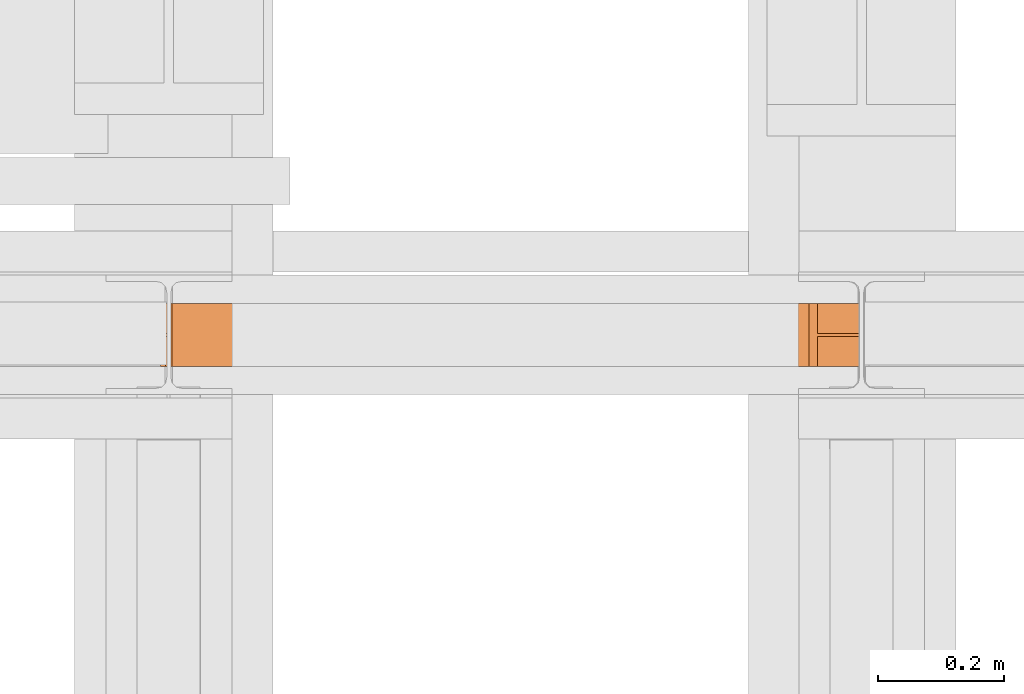
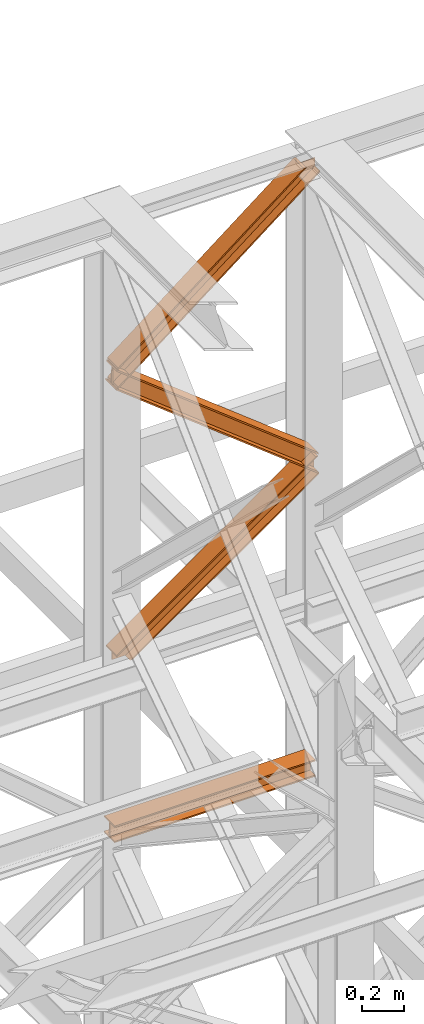
# One storey, part 105 of 208: 4 proxies.
"""IFC2X3 building model written with IfcOpenShell, lengths in millimetres."""

from ifc_helpers import new_model, entity, si_unit, converted_unit, frame, origin, origin_with_axes, place, context, subcontext, project, spatial, faceted_brep, element, save


model = new_model("IFC2X3")

# Units and contexts
model_context = context("Model", 3, precision=1e-05, world=origin())
plan_context = context("Plan", 3, precision=1e-05, world=origin())
body_context = subcontext(model_context, "Body", "Model", "MODEL_VIEW")
ifc_project = project(units=[si_unit("LENGTHUNIT", "METRE", prefix="MILLI"), converted_unit("PLANEANGLEUNIT", "DEGREE", entity("IfcPlaneAngleMeasure", 0.0174532925199433), si_unit("PLANEANGLEUNIT", "RADIAN"), dimensions=[0, 0, 0, 0, 0, 0, 0]), si_unit("AREAUNIT", "SQUARE_METRE"), si_unit("VOLUMEUNIT", "CUBIC_METRE")], contexts=[model_context, plan_context])

# Building, storey
building_placement = place(None, origin())
building = spatial("IfcBuilding", under=ifc_project, at=building_placement, CompositionType="COMPLEX")
storey_placement = place(building_placement, origin_with_axes())
storey = spatial("IfcBuildingStorey", under=building, at=storey_placement, Name="Geschoss", CompositionType="ELEMENT")

# Proxies
proxy_1_placement = place(storey_placement, frame((-1108.858001624428, -13812.50587051042, 9806.105713222338), z_axis=(0.0, 0.0, 1.0), x_axis=(1.0, 0.0, 0.0)))
element("IfcBuildingElementProxy", 1, at=proxy_1_placement, inside=storey, context=body_context, shape_type="Brep", body=[
    faceted_brep([(1100.142174177699, 0.01000000000021828, 722.8260713394575), (1100.142174177699, 0.01000000000021828, 713.1663213035336), (86.64349926533555, 0.01000000000203727, 0.01000000000749424), (72.98716220012079, 0.01000000001658918, 0.01000000000749424), (1100.142174177699, 0.01000000000021828, 713.1663213035336), (1100.142174177699, 100.0100000000075, 713.1663213035299), (86.64349926533555, 100.0100000000093, 0.01000000000385626), (86.64349926533555, 0.01000000000203727, 0.01000000000749424), (1100.142174177699, 100.0100000000075, 713.1663213035299), (1100.142174177699, 100.0100000000002, 722.8260713394575), (72.98716220012079, 100.0100000000166, 0.01000000000749424), (86.64349926533555, 100.0100000000093, 0.01000000000385626), (1100.142174177699, 100.0100000000002, 722.8260713394575), (1100.142174177707, 52.51000000000749, 722.8260713394611), (72.98716220010624, 52.51000000001659, 0.01000000000021828), (72.98716220012079, 100.0100000000166, 0.01000000000749424), (1100.142174177707, 52.51000000000749, 722.8260713394611), (1100.142174177699, 52.51000000000022, 816.8993256061676), (1096.441923246353, 52.51000000000022, 816.9654442141236), (0.01000000000726686, 52.51000000001659, 44.7291489489744), (0.01000000001454282, 52.51000000001659, 0.01000000000749424), (72.98716220010624, 52.51000000001659, 0.01000000000021828), (1096.441923246353, 52.51000000000022, 816.9654442141236), (1096.441923246353, 100.0100000000002, 816.96544421412), (0.01000000000726686, 100.0100000000093, 44.7291489489744), (0.01000000000726686, 52.51000000001659, 44.7291489489744), (1096.441923246353, 100.0100000000002, 816.96544421412), (1083.029589789743, 100.0100000000002, 817.2051049382371), (0.01000000000726686, 100.0100000000093, 54.33717683089526), (0.01000000000726686, 100.0100000000093, 44.7291489489744), (1083.029589789743, 100.0100000000002, 817.2051049382371), (1083.029589789743, 0.01000000000021828, 817.2051049382371), (0.01000000000726686, 0.01000000001658918, 54.33717683089526), (0.01000000000726686, 100.0100000000093, 54.33717683089526), (1083.029589789743, 0.01000000000021828, 817.2051049382371), (1096.441923246353, 0.01000000000021828, 816.9654442141236), (0.01000000000726686, 0.01000000001658918, 44.7291489489744), (0.01000000000726686, 0.01000000001658918, 54.33717683089526), (1096.441923246353, 0.01000000000021828, 816.9654442141236), (1096.441923246353, 47.51000000000022, 816.96544421412), (0.01000000000726686, 47.51000000001659, 44.72914894897076), (0.01000000000726686, 0.01000000001658918, 44.7291489489744), (1096.441923246353, 47.51000000000022, 816.96544421412), (1100.142174177699, 47.51000000000022, 816.899325606164), (1100.142174177699, 47.51000000000022, 722.8260713394575), (72.98716220012079, 47.51000000001659, 0.01000000000749424), (0.009999999999990905, 47.51000000002387, 0.01000000000749424), (0.01000000000726686, 47.51000000001659, 44.72914894897076), (1100.142174177699, 47.51000000000022, 722.8260713394575), (1100.142174177699, 0.01000000000021828, 722.8260713394575), (72.98716220012079, 0.01000000001658918, 0.01000000000749424), (72.98716220012079, 47.51000000001659, 0.01000000000749424), (1100.142174177699, 52.51000000000022, 816.8993256061676), (1100.142174177699, 47.51000000000022, 816.899325606164), (1096.441923246353, 47.51000000000022, 816.96544421412), (1096.441923246353, 0.01000000000021828, 816.9654442141236), (1083.029589789743, 0.01000000000021828, 817.2051049382371), (1083.029589789743, 100.0100000000002, 817.2051049382371), (1096.441923246353, 100.0100000000002, 816.96544421412), (1096.441923246353, 52.51000000000022, 816.9654442141236), (0.009999999999990905, 47.51000000002387, 0.01000000000749424), (0.01000000001454282, 52.51000000001659, 0.01000000000749424), (0.01000000000726686, 52.51000000001659, 44.7291489489744), (0.01000000000726686, 100.0100000000093, 44.7291489489744), (0.01000000000726686, 100.0100000000093, 54.33717683089526), (0.01000000000726686, 0.01000000001658918, 54.33717683089526), (0.01000000000726686, 0.01000000001658918, 44.7291489489744), (0.01000000000726686, 47.51000000001659, 44.72914894897076), (72.98716220012079, 0.01000000001658918, 0.01000000000749424), (86.64349926533555, 0.01000000000203727, 0.01000000000749424), (86.64349926533555, 100.0100000000093, 0.01000000000385626), (72.98716220012079, 100.0100000000166, 0.01000000000749424), (72.98716220010624, 52.51000000001659, 0.01000000000021828), (0.01000000001454282, 52.51000000001659, 0.01000000000749424), (0.009999999999990905, 47.51000000002387, 0.01000000000749424), (72.98716220012079, 47.51000000001659, 0.01000000000749424), (1100.142174177699, 0.01000000000021828, 713.1663213035336), (1100.142174177699, 0.01000000000021828, 722.8260713394575), (1100.142174177699, 47.51000000000022, 722.8260713394575), (1100.142174177699, 47.51000000000022, 816.899325606164), (1100.142174177699, 52.51000000000022, 816.8993256061676), (1100.142174177707, 52.51000000000749, 722.8260713394611), (1100.142174177699, 100.0100000000002, 722.8260713394575), (1100.142174177699, 100.0100000000075, 713.1663213035299)], [[[0, 1, 2, 3]], [[4, 5, 6, 7]], [[8, 9, 10, 11]], [[12, 13, 14, 15]], [[16, 17, 18, 19, 20, 21]], [[22, 23, 24, 25]], [[26, 27, 28, 29]], [[30, 31, 32, 33]], [[34, 35, 36, 37]], [[38, 39, 40, 41]], [[42, 43, 44, 45, 46, 47]], [[48, 49, 50, 51]], [[52, 53, 54, 55, 56, 57, 58, 59]], [[60, 61, 62, 63, 64, 65, 66, 67]], [[68, 69, 70, 71, 72, 73, 74, 75]], [[76, 77, 78, 79, 80, 81, 82, 83]]], orient=[[False], [False], [False], [False], [False], [False], [False], [False], [False], [False], [False], [False], [False], [False], [False], [False]]),
])
proxy_2_placement = place(storey_placement, frame((-1112.331256219962, -13812.50587051044, 10523.39186073946), z_axis=(0.0, 0.0, 1.0), x_axis=(1.0, 0.0, 0.0)))
element("IfcBuildingElementProxy", 2, at=proxy_2_placement, inside=storey, context=body_context, shape_type="Brep", body=[
    faceted_brep([(1100.481676374647, 0.01000000000749424, 119.7739453356207), (1100.481676374647, 0.01000000000021828, 109.7936165576484), (4.293078582855515, 0.01000000002386514, 970.1322548590924), (4.682449363119076, 0.01000000002386514, 979.8069877500366), (1100.481676374655, 100.0100000000002, 119.7739453356171), (1100.481676374647, 0.01000000000749424, 119.7739453356207), (4.682449363119076, 0.01000000002386514, 979.8069877500366), (4.682449363119076, 100.0100000000239, 979.8069877500366), (1100.481676374655, 100.0100000000002, 109.7936165576484), (1100.481676374655, 100.0100000000002, 119.7739453356171), (4.682449363119076, 100.0100000000239, 979.8069877500366), (4.29307858286279, 100.0100000000239, 970.1322548590924), (1100.481676374655, 52.51000000000022, 109.7936165576448), (1100.481676374655, 100.0100000000002, 109.7936165576484), (4.29307858286279, 100.0100000000239, 970.1322548590924), (4.293078582855515, 52.51000000002387, 970.1322548590924), (1100.481676374655, 52.51000000000749, 9.99032877796526), (1100.481676374655, 52.51000000000022, 109.7936165576448), (4.293078582855515, 52.51000000002387, 970.1322548590924), (0.3993707802635527, 52.51000000002387, 873.384925949611), (1100.481676374655, 100.0100000000075, 9.990328777968898), (1100.481676374655, 52.51000000000749, 9.99032877796526), (0.3993707802635527, 52.51000000002387, 873.384925949611), (0.3993707802562767, 100.0100000000239, 873.3849259496146), (1100.481676374655, 100.0100000000075, 0.01000000000385626), (1100.481676374655, 100.0100000000075, 9.990328777968898), (0.3993707802562767, 100.0100000000239, 873.3849259496146), (0.009999999999990905, 100.0100000000239, 863.7101930586632), (1100.481676374647, 0.01000000000749424, 0.01000000000021828), (1100.481676374655, 100.0100000000075, 0.01000000000385626), (0.009999999999990905, 100.0100000000239, 863.7101930586632), (0.009999999999990905, 0.01000000002386514, 863.7101930586632), (1100.481676374655, 0.01000000000021828, 9.99032877796526), (1100.481676374647, 0.01000000000749424, 0.01000000000021828), (0.009999999999990905, 0.01000000002386514, 863.7101930586632), (0.3993707802562767, 0.01000000002386514, 873.384925949611), (1100.481676374655, 47.51000000000749, 9.990328777968898), (1100.481676374655, 0.01000000000021828, 9.99032877796526), (0.3993707802562767, 0.01000000002386514, 873.384925949611), (0.3993707802562767, 47.51000000002387, 873.384925949611), (1100.481676374647, 47.51000000000022, 109.7936165576448), (1100.481676374655, 47.51000000000749, 9.990328777968898), (0.3993707802562767, 47.51000000002387, 873.384925949611), (4.293078582855515, 47.51000000002387, 970.1322548590924), (1100.481676374647, 0.01000000000021828, 109.7936165576484), (1100.481676374647, 47.51000000000022, 109.7936165576448), (4.293078582855515, 47.51000000002387, 970.1322548590924), (4.293078582855515, 0.01000000002386514, 970.1322548590924), (4.293078582855515, 0.01000000002386514, 970.1322548590924), (4.293078582855515, 47.51000000002387, 970.1322548590924), (0.3993707802562767, 47.51000000002387, 873.384925949611), (0.3993707802562767, 0.01000000002386514, 873.384925949611), (0.009999999999990905, 0.01000000002386514, 863.7101930586632), (0.009999999999990905, 100.0100000000239, 863.7101930586632), (0.3993707802562767, 100.0100000000239, 873.3849259496146), (0.3993707802635527, 52.51000000002387, 873.384925949611), (4.293078582855515, 52.51000000002387, 970.1322548590924), (4.29307858286279, 100.0100000000239, 970.1322548590924), (4.682449363119076, 100.0100000000239, 979.8069877500366), (4.682449363119076, 0.01000000002386514, 979.8069877500366), (1100.481676374647, 0.01000000000021828, 109.7936165576484), (1100.481676374647, 0.01000000000749424, 119.7739453356207), (1100.481676374655, 100.0100000000002, 119.7739453356171), (1100.481676374655, 100.0100000000002, 109.7936165576484), (1100.481676374655, 52.51000000000022, 109.7936165576448), (1100.481676374655, 52.51000000000749, 9.99032877796526), (1100.481676374655, 100.0100000000075, 9.990328777968898), (1100.481676374655, 100.0100000000075, 0.01000000000385626), (1100.481676374647, 0.01000000000749424, 0.01000000000021828), (1100.481676374655, 0.01000000000021828, 9.99032877796526), (1100.481676374655, 47.51000000000749, 9.990328777968898), (1100.481676374647, 47.51000000000022, 109.7936165576448)], [[[0, 1, 2, 3]], [[4, 5, 6, 7]], [[8, 9, 10, 11]], [[12, 13, 14, 15]], [[16, 17, 18, 19]], [[20, 21, 22, 23]], [[24, 25, 26, 27]], [[28, 29, 30, 31]], [[32, 33, 34, 35]], [[36, 37, 38, 39]], [[40, 41, 42, 43]], [[44, 45, 46, 47]], [[48, 49, 50, 51, 52, 53, 54, 55, 56, 57, 58, 59]], [[60, 61, 62, 63, 64, 65, 66, 67, 68, 69, 70, 71]]], orient=[[False], [False], [False], [False], [False], [False], [False], [False], [False], [False], [False], [False], [False], [False]]),
])
proxy_3_placement = place(storey_placement, frame((-1101.630483097373, -13812.50587051044, 11391.82335629927), z_axis=(0.0, 0.0, 1.0), x_axis=(1.0, 0.0, 0.0)))
element("IfcBuildingElementProxy", 3, at=proxy_3_placement, inside=storey, context=body_context, shape_type="Brep", body=[
    faceted_brep([(1097.835867414895, 0.01000000000203727, 871.613970700977), (1097.835867414895, 0.01000000000385626, 861.6336419230047), (0.01000000000726686, 0.0100000000311411, 0.01000000000021828), (0.009999999999990905, 0.01000000002386514, 9.99032877796526), (1097.835867414895, 0.01000000000385626, 861.6336419230047), (1097.835867414895, 100.0100000000039, 861.6336419230047), (0.01000000000726686, 100.0100000000311, 0.01000000000021828), (0.01000000000726686, 0.0100000000311411, 0.01000000000021828), (1097.835867414895, 100.0100000000039, 861.6336419230047), (1097.835867414895, 100.010000000002, 871.613970700977), (0.009999999999990905, 100.0100000000311, 9.99032877796526), (0.01000000000726686, 100.0100000000311, 0.01000000000021828), (1097.835867414895, 100.010000000002, 871.613970700977), (1097.835867414895, 52.51000000000204, 871.613970700977), (0.009999999999990905, 52.51000000002387, 9.99032877796526), (0.009999999999990905, 100.0100000000311, 9.99032877796526), (1097.835867414895, 52.51000000000204, 871.613970700977), (1097.835867414895, 52.51000000000022, 916.9062352682795), (1024.627333509523, 52.51000000000022, 913.9598734110823), (0.009999999999990905, 52.51000000003114, 109.7936165576448), (0.009999999999990905, 52.51000000002387, 9.99032877796526), (1024.627333509523, 52.51000000000022, 913.9598734110823), (1024.627333509523, 100.0100000000002, 913.9598734110787), (0.009999999999990905, 100.0100000000311, 109.7936165576448), (0.009999999999990905, 52.51000000003114, 109.7936165576448), (1024.627333509523, 100.0100000000002, 913.9598734110787), (1011.223709899639, 100.0100000000002, 913.4204291243896), (0.009999999999990905, 100.0100000000311, 119.7739453356062), (0.009999999999990905, 100.0100000000311, 109.7936165576448), (1011.223709899639, 100.0100000000002, 913.4204291243896), (1011.223709899639, 0.01000000000021828, 913.4204291243896), (0.009999999999990905, 0.0100000000311411, 119.7739453356135), (0.009999999999990905, 100.0100000000311, 119.7739453356062), (1011.223709899639, 0.01000000000021828, 913.4204291243896), (1024.627333509523, 0.01000000000021828, 913.9598734110823), (0.009999999999990905, 0.0100000000311411, 109.7936165576448), (0.009999999999990905, 0.0100000000311411, 119.7739453356135), (1024.627333509523, 0.01000000000021828, 913.9598734110823), (1024.627333509523, 47.51000000000022, 913.9598734110787), (0.009999999999990905, 47.51000000003114, 109.7936165576448), (0.009999999999990905, 0.0100000000311411, 109.7936165576448), (1024.627333509523, 47.51000000000022, 913.9598734110787), (1097.835867414895, 47.51000000000022, 916.9062352682759), (1097.835867414895, 47.51000000000204, 871.613970700977), (0.009999999999990905, 47.51000000003114, 9.990328777961622), (0.009999999999990905, 47.51000000003114, 109.7936165576448), (1097.835867414895, 47.51000000000204, 871.613970700977), (1097.835867414895, 0.01000000000203727, 871.613970700977), (0.009999999999990905, 0.01000000002386514, 9.99032877796526), (0.009999999999990905, 47.51000000003114, 9.990328777961622), (1097.835867414895, 52.51000000000022, 916.9062352682795), (1097.835867414895, 47.51000000000022, 916.9062352682759), (1024.627333509523, 47.51000000000022, 913.9598734110787), (1024.627333509523, 0.01000000000021828, 913.9598734110823), (1011.223709899639, 0.01000000000021828, 913.4204291243896), (1011.223709899639, 100.0100000000002, 913.4204291243896), (1024.627333509523, 100.0100000000002, 913.9598734110787), (1024.627333509523, 52.51000000000022, 913.9598734110823), (0.009999999999990905, 0.01000000002386514, 9.99032877796526), (0.01000000000726686, 0.0100000000311411, 0.01000000000021828), (0.01000000000726686, 100.0100000000311, 0.01000000000021828), (0.009999999999990905, 100.0100000000311, 9.99032877796526), (0.009999999999990905, 52.51000000002387, 9.99032877796526), (0.009999999999990905, 52.51000000003114, 109.7936165576448), (0.009999999999990905, 100.0100000000311, 109.7936165576448), (0.009999999999990905, 100.0100000000311, 119.7739453356062), (0.009999999999990905, 0.0100000000311411, 119.7739453356135), (0.009999999999990905, 0.0100000000311411, 109.7936165576448), (0.009999999999990905, 47.51000000003114, 109.7936165576448), (0.009999999999990905, 47.51000000003114, 9.990328777961622), (1097.835867414895, 0.01000000000385626, 861.6336419230047), (1097.835867414895, 0.01000000000203727, 871.613970700977), (1097.835867414895, 47.51000000000204, 871.613970700977), (1097.835867414895, 47.51000000000022, 916.9062352682759), (1097.835867414895, 52.51000000000022, 916.9062352682795), (1097.835867414895, 52.51000000000204, 871.613970700977), (1097.835867414895, 100.010000000002, 871.613970700977), (1097.835867414895, 100.0100000000039, 861.6336419230047)], [[[0, 1, 2, 3]], [[4, 5, 6, 7]], [[8, 9, 10, 11]], [[12, 13, 14, 15]], [[16, 17, 18, 19, 20]], [[21, 22, 23, 24]], [[25, 26, 27, 28]], [[29, 30, 31, 32]], [[33, 34, 35, 36]], [[37, 38, 39, 40]], [[41, 42, 43, 44, 45]], [[46, 47, 48, 49]], [[50, 51, 52, 53, 54, 55, 56, 57]], [[58, 59, 60, 61, 62, 63, 64, 65, 66, 67, 68, 69]], [[70, 71, 72, 73, 74, 75, 76, 77]]], orient=[[False], [False], [False], [False], [False], [False], [False], [False], [False], [False], [False], [False], [False], [False], [False]]),
])
proxy_4_placement = place(storey_placement, frame((-1119.921154293107, -13812.50587051042, 8785.007354628784), z_axis=(0.0, 0.0, 1.0), x_axis=(1.0, 0.0, 0.0)))
element("IfcBuildingElementProxy", 4, at=proxy_4_placement, inside=storey, context=body_context, shape_type="Brep", body=[
    faceted_brep([(1091.936120735611, 0.01000000000021828, 88.01000000000022), (1091.936120735611, 0.01000000000021828, 96.01000000000022), (1091.936120735611, 100.0100000000002, 96.01000000000022), (1091.936120735611, 100.0100000000002, 88.01000000000022), (1091.936120735611, 52.51000000000022, 88.01000000000022), (1091.936120735611, 52.51000000000022, 8.010000000000218), (1091.936120735611, 100.0100000000002, 8.010000000000218), (1091.936120735611, 100.0100000000002, 0.01000000000021828), (1091.936120735611, 0.01000000000021828, 0.01000000000021828), (1091.936120735611, 0.01000000000021828, 8.010000000000218), (1091.936120735611, 47.51000000000022, 8.010000000000218), (1091.936120735611, 47.51000000000022, 88.01000000000022), (1091.936120735611, 0.01000000000021828, 96.01000000000022), (1091.936120735611, 0.01000000000021828, 88.01000000000022), (0.009999999999990905, 0.01000000000385626, 88.01000000000022), (0.009999999999990905, 0.01000000000385626, 96.01000000000022), (1091.936120735611, 100.0100000000002, 96.01000000000022), (1091.936120735611, 0.01000000000021828, 96.01000000000022), (0.009999999999990905, 0.01000000000385626, 96.01000000000022), (0.009999999999990905, 100.0100000000039, 96.01000000000022), (1091.936120735611, 100.0100000000002, 88.01000000000022), (1091.936120735611, 100.0100000000002, 96.01000000000022), (0.009999999999990905, 100.0100000000039, 96.01000000000022), (0.009999999999990905, 100.0100000000039, 88.01000000000022), (1091.936120735611, 52.51000000000022, 88.01000000000022), (1091.936120735611, 100.0100000000002, 88.01000000000022), (0.009999999999990905, 100.0100000000039, 88.01000000000022), (0.009999999999990905, 52.51000000000386, 88.01000000000022), (1091.936120735611, 52.51000000000022, 8.010000000000218), (1091.936120735611, 52.51000000000022, 88.01000000000022), (0.009999999999990905, 52.51000000000386, 88.01000000000022), (0.009999999999990905, 52.51000000000386, 8.010000000000218), (1091.936120735611, 100.0100000000002, 8.010000000000218), (1091.936120735611, 52.51000000000022, 8.010000000000218), (0.009999999999990905, 52.51000000000386, 8.010000000000218), (0.009999999999990905, 100.0100000000039, 8.010000000000218), (1091.936120735611, 100.0100000000002, 0.01000000000021828), (1091.936120735611, 100.0100000000002, 8.010000000000218), (0.009999999999990905, 100.0100000000039, 8.010000000000218), (0.009999999999990905, 100.0100000000039, 0.01000000000021828), (1091.936120735611, 0.01000000000021828, 0.01000000000021828), (1091.936120735611, 100.0100000000002, 0.01000000000021828), (0.009999999999990905, 100.0100000000039, 0.01000000000021828), (0.009999999999990905, 0.01000000000385626, 0.01000000000021828), (1091.936120735611, 0.01000000000021828, 8.010000000000218), (1091.936120735611, 0.01000000000021828, 0.01000000000021828), (0.009999999999990905, 0.01000000000385626, 0.01000000000021828), (0.009999999999990905, 0.01000000000385626, 8.010000000000218), (1091.936120735611, 47.51000000000022, 8.010000000000218), (1091.936120735611, 0.01000000000021828, 8.010000000000218), (0.009999999999990905, 0.01000000000385626, 8.010000000000218), (0.009999999999990905, 47.51000000000386, 8.010000000000218), (1091.936120735611, 47.51000000000022, 88.01000000000022), (1091.936120735611, 47.51000000000022, 8.010000000000218), (0.009999999999990905, 47.51000000000386, 8.010000000000218), (0.009999999999990905, 47.51000000000386, 88.01000000000022), (1091.936120735611, 0.01000000000021828, 88.01000000000022), (1091.936120735611, 47.51000000000022, 88.01000000000022), (0.009999999999990905, 47.51000000000386, 88.01000000000022), (0.009999999999990905, 0.01000000000385626, 88.01000000000022), (0.009999999999990905, 0.01000000000385626, 88.01000000000022), (0.009999999999990905, 47.51000000000386, 88.01000000000022), (0.009999999999990905, 47.51000000000386, 8.010000000000218), (0.009999999999990905, 0.01000000000385626, 8.010000000000218), (0.009999999999990905, 0.01000000000385626, 0.01000000000021828), (0.009999999999990905, 100.0100000000039, 0.01000000000021828), (0.009999999999990905, 100.0100000000039, 8.010000000000218), (0.009999999999990905, 52.51000000000386, 8.010000000000218), (0.009999999999990905, 52.51000000000386, 88.01000000000022), (0.009999999999990905, 100.0100000000039, 88.01000000000022), (0.009999999999990905, 100.0100000000039, 96.01000000000022), (0.009999999999990905, 0.01000000000385626, 96.01000000000022)], [[[0, 1, 2, 3, 4, 5, 6, 7, 8, 9, 10, 11]], [[12, 13, 14, 15]], [[16, 17, 18, 19]], [[20, 21, 22, 23]], [[24, 25, 26, 27]], [[28, 29, 30, 31]], [[32, 33, 34, 35]], [[36, 37, 38, 39]], [[40, 41, 42, 43]], [[44, 45, 46, 47]], [[48, 49, 50, 51]], [[52, 53, 54, 55]], [[56, 57, 58, 59]], [[60, 61, 62, 63, 64, 65, 66, 67, 68, 69, 70, 71]]], orient=[[False], [False], [False], [False], [False], [False], [False], [False], [False], [False], [False], [False], [False], [False]]),
])

save(model, "model.ifc")
